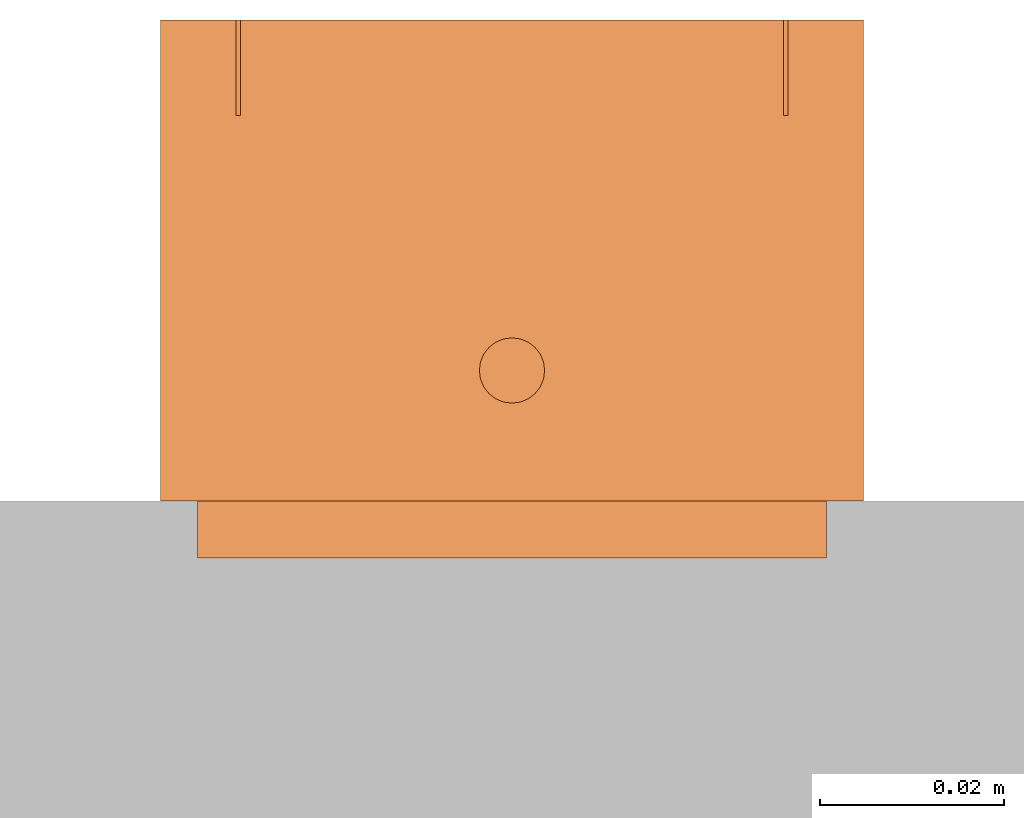
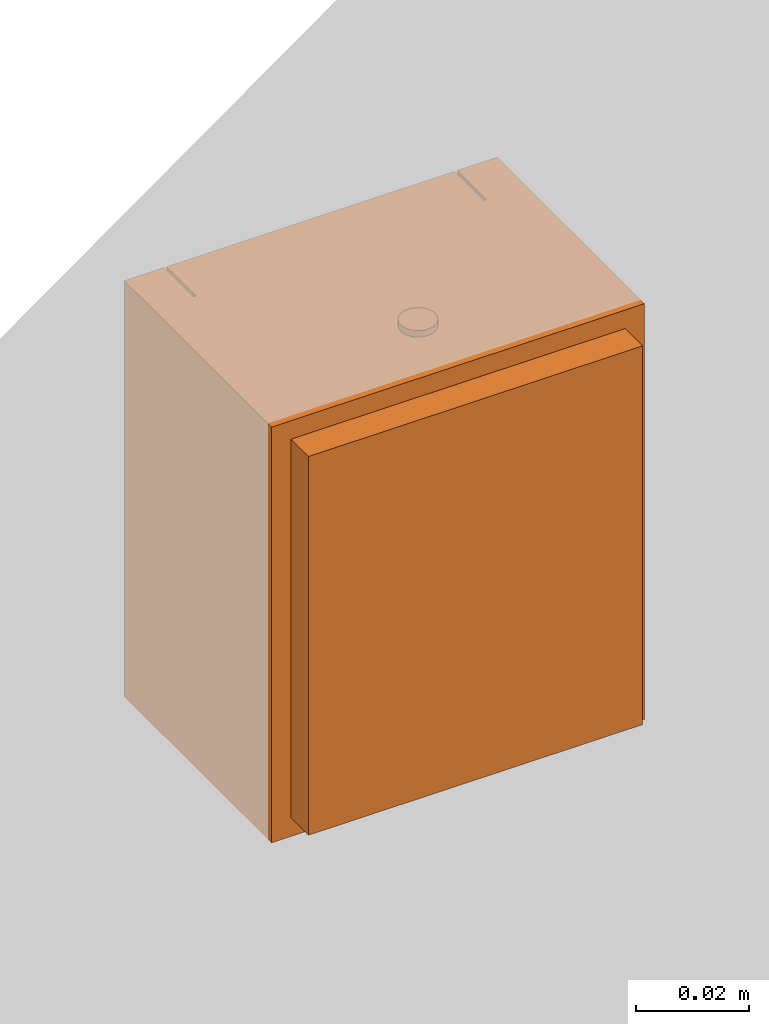
# One storey, part 2 of 2: 1 proxy.
"""IFC2X3 building model written with IfcOpenShell, lengths in millimetres."""

from ifc_helpers import new_model, entity, si_unit, converted_unit, derived_unit, direction, frame, origin, place, context, subcontext, project, spatial, faceted_brep, source, transform, mapped, material, type_object, type_shapes, element, save


model = new_model("IFC2X3")

# Units and contexts
model_context = context("Model", 3, precision=0.01, world=origin(), true_north=direction((6.12303176911189e-17, 1.0)))
body_context = subcontext(model_context, "Body", "Model", "MODEL_VIEW")
ifc_project = project(units=[si_unit("LENGTHUNIT", "METRE", prefix="MILLI"), si_unit("AREAUNIT", "SQUARE_METRE"), si_unit("VOLUMEUNIT", "CUBIC_METRE"), converted_unit("PLANEANGLEUNIT", "DEGREE", entity("IfcRatioMeasure", 0.0174532925199433), si_unit("PLANEANGLEUNIT", "RADIAN"), dimensions=[0, 0, 0, 0, 0, 0, 0]), si_unit("MASSUNIT", "GRAM", prefix="KILO"), derived_unit("MASSDENSITYUNIT", [(si_unit("MASSUNIT", "GRAM", prefix="KILO"), 1), (si_unit("LENGTHUNIT", "METRE"), -3)]), si_unit("TIMEUNIT", "SECOND"), si_unit("FREQUENCYUNIT", "HERTZ"), si_unit("THERMODYNAMICTEMPERATUREUNIT", "DEGREE_CELSIUS"), derived_unit("THERMALTRANSMITTANCEUNIT", [(si_unit("MASSUNIT", "GRAM", prefix="KILO"), 1), (si_unit("THERMODYNAMICTEMPERATUREUNIT", "KELVIN"), -1), (si_unit("TIMEUNIT", "SECOND"), -3)]), derived_unit("VOLUMETRICFLOWRATEUNIT", [(si_unit("LENGTHUNIT", "METRE"), 3), (si_unit("TIMEUNIT", "SECOND"), -1)]), si_unit("ELECTRICCURRENTUNIT", "AMPERE"), si_unit("ELECTRICVOLTAGEUNIT", "VOLT"), si_unit("POWERUNIT", "WATT"), si_unit("FORCEUNIT", "NEWTON", prefix="KILO"), si_unit("ILLUMINANCEUNIT", "LUX"), si_unit("LUMINOUSFLUXUNIT", "LUMEN"), si_unit("LUMINOUSINTENSITYUNIT", "CANDELA"), derived_unit("USERDEFINED", [(si_unit("MASSUNIT", "GRAM", prefix="KILO"), -1), (si_unit("LENGTHUNIT", "METRE"), -2), (si_unit("TIMEUNIT", "SECOND"), 3), (si_unit("LUMINOUSFLUXUNIT", "LUMEN"), 1)]), derived_unit("LINEARVELOCITYUNIT", [(si_unit("LENGTHUNIT", "METRE"), 1), (si_unit("TIMEUNIT", "SECOND"), -1)]), si_unit("PRESSUREUNIT", "PASCAL"), derived_unit("USERDEFINED", [(si_unit("LENGTHUNIT", "METRE"), -2), (si_unit("MASSUNIT", "GRAM", prefix="KILO"), 1), (si_unit("TIMEUNIT", "SECOND"), -2)])], contexts=[model_context])

# Site, building, storey
site_placement = place(None, origin())
site = spatial("IfcSite", under=ifc_project, at=site_placement, CompositionType="ELEMENT")
building_placement = place(site_placement, origin())
building = spatial("IfcBuilding", under=site, at=building_placement, CompositionType="ELEMENT")
storey_placement = place(building_placement, origin())
storey = spatial("IfcBuildingStorey", under=building, at=storey_placement, Name="Ebene 1", CompositionType="ELEMENT", Elevation=0.0)

# Proxy
ifc_material = material(Name="White")
building_element_proxy_type = type_object("IfcBuildingElementProxyType", PredefinedType="NOTDEFINED", material=ifc_material)
shared_shape = source(origin(), body_context, "Body", "Brep", [
    faceted_brep([(67.7, 48.0999999999999, 9.09999999999752), (67.7, 58.1, 10.8632698070822), (67.7, 53.9146115753526, 70.7171128226717), (67.7, 48.1, 72.0999999999975), (8.70000000000002, 48.0999999999999, 9.09999999999752), (8.70000000000002, 48.1, 72.0999999999975), (8.70000000000002, 53.9146115753526, 70.7171128226717), (8.70000000000002, 58.1, 10.8632698070822)], [[[0, 1, 2, 3]], [[4, 5, 6, 7]], [[1, 0, 4, 7]], [[2, 1, 7, 6]], [[3, 2, 6, 5]], [[0, 3, 5, 4]]]),
    faceted_brep([(41.9, 57.3671158199917, 39.0), (34.4999999999999, 57.3671158199917, 39.0), (32.1999999999999, 57.3671158199917, 41.3), (34.4999999999999, 57.3671158199917, 43.6), (41.9, 57.3671158199917, 43.6), (44.2, 57.3671158199917, 41.3), (41.9, 48.1, 43.6), (34.4999999999999, 48.1, 43.6), (32.1999999999999, 48.1, 41.3), (34.4999999999999, 48.1, 39.0), (41.9, 48.1, 39.0), (44.2, 48.1, 41.3)], [[[0, 1, 2, 3, 4, 5]], [[6, 7, 8, 9, 10, 11]], [[7, 3, 2, 8]], [[2, 1, 9, 8]], [[10, 9, 1, 0]], [[10, 0, 5, 11]], [[5, 4, 6, 11]], [[7, 6, 4, 3]]]),
    faceted_brep([(76.4000000000001, 58.5, 90.0), (76.4000000000001, 58.5, 0.0), (0.0, 58.5, 0.0), (0.0, 58.5, 90.0), (8.20000000000001, 58.5, 90.0), (8.20000000000001, 58.5, 8.60000000000002), (68.2, 58.5, 8.60000000000001), (68.2, 58.5, 90.0), (0.0, 6.20000000000001, 90.0), (0.0, 6.20000000000001, 0.0), (76.4000000000001, 6.20000000000001, 0.0), (76.4000000000001, 6.20000000000001, 90.0), (68.2, 48.1, 90.0), (8.20000000000001, 48.1, 90.0), (68.2, 48.1, 8.60000000000001), (8.20000000000001, 48.1, 8.60000000000002)], [[[0, 1, 2, 3, 4, 5, 6, 7]], [[8, 9, 10, 11]], [[3, 2, 9, 8]], [[2, 1, 10, 9]], [[1, 0, 11, 10]], [[8, 11, 0, 7, 12, 13, 4, 3]], [[14, 15, 13, 12]], [[13, 15, 5, 4]], [[15, 14, 6, 5]], [[14, 12, 7, 6]]]),
    faceted_brep([(67.7, 48.1, 85.0), (8.70000000000002, 48.1, 85.0), (8.70000000000002, 48.1, 72.0), (67.7, 48.1, 72.0), (67.7, 58.5, 85.0), (67.7, 58.5, 72.0), (8.70000000000002, 58.5, 72.0), (8.70000000000002, 58.5, 85.0)], [[[0, 1, 2, 3]], [[4, 5, 6, 7]], [[2, 1, 7, 6]], [[0, 3, 5, 4]], [[1, 0, 4, 7]], [[3, 2, 6, 5]]]),
    faceted_brep([(8.70000000000002, 48.1, 90.0), (8.70000000000002, 48.1, 85.5), (67.7, 48.1, 85.5), (67.7, 48.1, 90.0), (8.70000000000002, 58.5, 90.0), (67.7, 58.5, 90.0), (67.7, 58.5, 85.5), (8.70000000000002, 58.5, 85.5)], [[[0, 1, 2, 3]], [[4, 5, 6, 7]], [[1, 0, 4, 7]], [[2, 1, 7, 6]], [[3, 2, 6, 5]], [[0, 3, 5, 4]]]),
    faceted_brep([(41.6290366833266, 19.4811923898861, 91.4), (41.7500000000004, 20.4, 91.4), (41.6290366833266, 21.318807610114, 91.4), (41.2743901834352, 22.175, 91.4), (40.7102290732127, 22.9102290732123, 91.4), (39.9750000000004, 23.4743901834348, 91.4), (39.1188076101144, 23.8290366833262, 91.4), (38.2000000000004, 23.95, 91.4), (37.2811923898865, 23.8290366833262, 91.4), (36.4250000000004, 23.4743901834348, 91.4), (35.6897709267882, 22.9102290732123, 91.4), (35.1256098165657, 22.175, 91.4), (34.7709633166742, 21.318807610114, 91.4), (34.6500000000004, 20.4, 91.4), (34.7709633166742, 19.4811923898861, 91.4), (35.1256098165656, 18.625, 91.4), (35.6897709267882, 17.8897709267878, 91.4), (36.4250000000004, 17.3256098165653, 91.4), (37.2811923898864, 16.9709633166738, 91.4), (38.2000000000004, 16.85, 91.4), (39.1188076101144, 16.9709633166738, 91.4), (39.9750000000004, 17.3256098165653, 91.4), (40.7102290732127, 17.8897709267878, 91.4), (41.2743901834352, 18.625, 91.4), (38.2000000000004, 23.95, 90.0), (39.1188076101144, 23.8290366833262, 90.0), (39.9750000000004, 23.4743901834348, 90.0), (40.7102290732127, 22.9102290732123, 90.0), (41.2743901834352, 22.175, 90.0), (41.6290366833266, 21.318807610114, 90.0), (41.7500000000004, 20.4, 90.0), (41.6290366833266, 19.4811923898861, 90.0), (41.2743901834352, 18.625, 90.0), (40.7102290732127, 17.8897709267878, 90.0), (39.9750000000004, 17.3256098165653, 90.0), (39.1188076101144, 16.9709633166738, 90.0), (38.2000000000004, 16.85, 90.0), (37.2811923898864, 16.9709633166738, 90.0), (36.4250000000004, 17.3256098165653, 90.0), (35.6897709267882, 17.8897709267878, 90.0), (35.1256098165656, 18.625, 90.0), (34.7709633166742, 19.4811923898861, 90.0), (34.6500000000004, 20.4, 90.0), (34.7709633166742, 21.318807610114, 90.0), (35.1256098165657, 22.175, 90.0), (35.6897709267882, 22.9102290732123, 90.0), (36.4250000000004, 23.4743901834348, 90.0), (37.2811923898865, 23.8290366833262, 90.0)], [[[0, 1, 2, 3, 4, 5, 6, 7, 8, 9, 10, 11, 12, 13, 14, 15, 16, 17, 18, 19, 20, 21, 22, 23]], [[24, 25, 26, 27, 28, 29, 30, 31, 32, 33, 34, 35, 36, 37, 38, 39, 40, 41, 42, 43, 44, 45, 46, 47]], [[41, 14, 13, 42]], [[40, 15, 14, 41]], [[17, 16, 39, 38]], [[40, 39, 16, 15]], [[18, 17, 38, 37]], [[19, 18, 37, 36]], [[35, 20, 19, 36]], [[34, 21, 20, 35]], [[23, 22, 33, 32]], [[34, 33, 22, 21]], [[0, 23, 32, 31]], [[1, 0, 31, 30]], [[29, 2, 1, 30]], [[28, 3, 2, 29]], [[5, 4, 27, 26]], [[28, 27, 4, 3]], [[6, 5, 26, 25]], [[7, 6, 25, 24]], [[47, 8, 7, 24]], [[46, 9, 8, 47]], [[11, 10, 45, 44]], [[46, 45, 10, 9]], [[12, 11, 44, 43]], [[13, 12, 43, 42]]]),
    faceted_brep([(4.0, 0.0, 86.0), (4.0, 0.0, 4.0), (72.4000000000001, 0.0, 4.0), (72.4000000000001, 0.0, 86.0), (4.0, 6.20000000000001, 86.0), (72.4000000000001, 6.20000000000001, 86.0), (72.4000000000001, 6.20000000000001, 4.0), (4.0, 6.20000000000001, 4.0)], [[[0, 1, 2, 3]], [[4, 5, 6, 7]], [[1, 0, 4, 7]], [[2, 1, 7, 6]], [[3, 2, 6, 5]], [[0, 3, 5, 4]]]),
])
type_shapes(building_element_proxy_type, [shared_shape])
proxy_placement = place(storey_placement, frame((4465.72531740588, 2429.23444050743, 1949.41102531626)))
element("IfcBuildingElementProxy", 1, at=proxy_placement, inside=storey, type_object=building_element_proxy_type, material=ifc_material, context=body_context, shape_type="MappedRepresentation", body=[
    mapped(shared_shape, transform((0.0, 0.0, 0.0), scale=1.0)),
])

save(model, "model.ifc")
